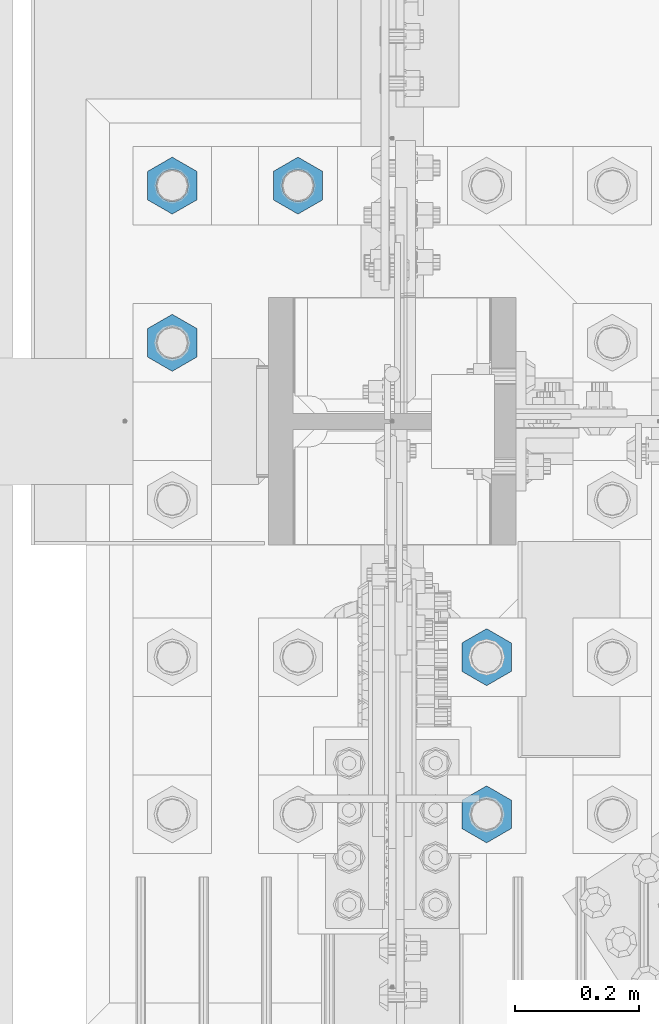
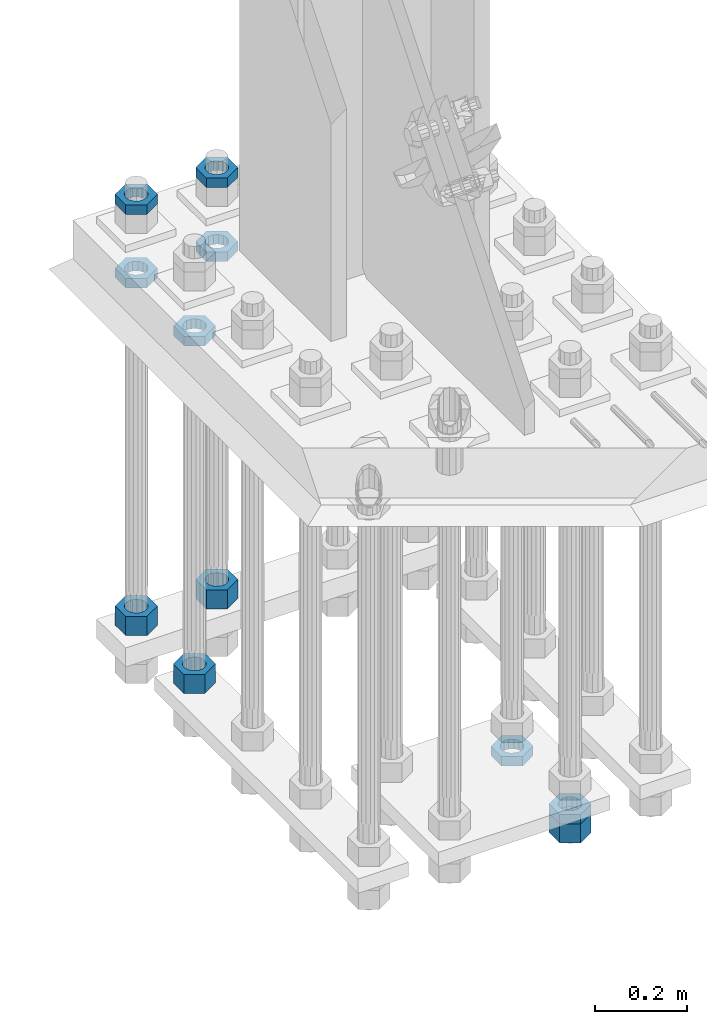
# One storey, part 2386 of 3843: 11 beams, 1 element without a shape of its own.
"""IFC2X3 building model written with IfcOpenShell, lengths in millimetres."""

from ifc_helpers import new_model, si_unit, frame, origin_with_axes, place, context, subcontext, project, spatial, faceted_brep, material, type_object, element, aggregate, save


model = new_model("IFC2X3")

# Units and contexts
model_context = context("Model", 3, precision=1e-05, world=origin_with_axes())
body_context = subcontext(model_context, "Body", "Model", "MODEL_VIEW")
ifc_project = project(units=[si_unit("LENGTHUNIT", "METRE", prefix="MILLI"), si_unit("AREAUNIT", "SQUARE_METRE"), si_unit("VOLUMEUNIT", "CUBIC_METRE"), si_unit("MASSUNIT", "GRAM", prefix="KILO"), si_unit("TIMEUNIT", "SECOND"), si_unit("PLANEANGLEUNIT", "RADIAN"), si_unit("SOLIDANGLEUNIT", "STERADIAN"), si_unit("THERMODYNAMICTEMPERATUREUNIT", "DEGREE_CELSIUS"), si_unit("LUMINOUSINTENSITYUNIT", "LUMEN")], contexts=[model_context])

# Site, building, storey
site_placement = place(None, origin_with_axes())
site = spatial("IfcSite", under=ifc_project, at=site_placement, CompositionType="ELEMENT")
building_placement = place(site_placement, origin_with_axes())
building = spatial("IfcBuilding", under=site, at=building_placement, Name="Undefined", CompositionType="ELEMENT")
storey_placement = place(building_placement, origin_with_axes())
storey = spatial("IfcBuildingStorey", under=building, at=storey_placement, Name="Undefined", CompositionType="ELEMENT", Elevation=0.0)

# Assembly, beams
assembly_placement = place(storey_placement, origin_with_axes())
assembly = element("IfcElementAssembly", 1, at=assembly_placement, inside=storey, Name="TEMPLATE", AssemblyPlace="NOTDEFINED", PredefinedType="RIGID_FRAME")
ifc_material = material(Name="STEEL/A572-50")
beam_type_1 = type_object("IfcBeamType", Name="2_HALF_NUT", PredefinedType="NOTDEFINED")
beam_1_placement = place(assembly_placement, frame((36220.4, 75755.5, 30060.9), z_axis=(1.0, 0.0, 0.0), x_axis=(0.0, 0.0, -1.0)))
beam_1 = element("IfcBeam", 2, at=beam_1_placement, type_object=beam_type_1, material=ifc_material, Name="NUT", ObjectType="2_HALF_NUT", context=body_context, shape_type="Brep", body=[
    faceted_brep([(0.0, -46.0369987487793, 0.0), (0.0, -23.0184993743896, -39.869213104248), (25.4000000000015, -23.0184993743896, -39.869213104248), (25.4000000000015, -46.0369987487793, 0.0), (0.0, 23.0184993743896, -39.869213104248), (25.4000000000015, 23.0184993743896, -39.869213104248), (0.0, 46.0369987487793, 0.0), (25.4000000000015, 46.0369987487793, 0.0), (0.0, 23.0184993743896, 39.869213104248), (25.4000000000015, 23.0184993743896, 39.869213104248), (0.0, -23.0184993743896, 39.869213104248), (25.4000000000015, -23.0184993743896, 39.869213104248), (0.0, 0.0, 26.1940002441406), (0.0, 11.3650617044477, 23.5999013092805), (25.4000000000015, 11.3650617044477, 23.5999013092805), (25.4000000000015, 0.0, 26.1940002441406), (0.0, 20.4791109456419, 16.3316083006721), (25.4000000000015, 20.4791109456419, 16.3316083006721), (0.0, 25.5370200498292, 5.82867859874386), (25.4000000000015, 25.5370200498292, 5.82867859874386), (0.0, 25.5370200498292, -5.82867859874386), (25.4000000000015, 25.5370200498292, -5.82867859874386), (0.0, 20.4791109456419, -16.3316083006721), (25.4000000000015, 20.4791109456419, -16.3316083006721), (0.0, 11.3650617044477, -23.5999013092805), (25.4000000000015, 11.3650617044477, -23.5999013092805), (0.0, 0.0, -26.1940002441406), (25.4000000000015, 0.0, -26.1940002441406), (0.0, -11.3650617044477, -23.5999013092805), (25.4000000000015, -11.3650617044477, -23.5999013092805), (0.0, -20.4791109456419, -16.3316083006721), (25.4000000000015, -20.4791109456419, -16.3316083006721), (0.0, -25.5370200498292, -5.82867859874386), (25.4000000000015, -25.5370200498292, -5.82867859874386), (0.0, -25.5370200498292, 5.82867859874386), (25.4000000000015, -25.5370200498292, 5.82867859874386), (0.0, -20.4791109456419, 16.3316083006721), (25.4000000000015, -20.4791109456419, 16.3316083006721), (0.0, -11.3650617044477, 23.5999013092805), (25.4000000000015, -11.3650617044477, 23.5999013092805)], [[[0, 1, 2, 3]], [[1, 4, 5, 2]], [[4, 6, 7, 5]], [[6, 8, 9, 7]], [[8, 10, 11, 9]], [[10, 0, 3, 11]], [[12, 13, 14, 15]], [[13, 16, 17, 14]], [[16, 18, 19, 17]], [[18, 20, 21, 19]], [[20, 22, 23, 21]], [[22, 24, 25, 23]], [[24, 26, 27, 25]], [[26, 28, 29, 27]], [[28, 30, 31, 29]], [[30, 32, 33, 31]], [[32, 34, 35, 33]], [[34, 36, 37, 35]], [[36, 38, 39, 37]], [[38, 12, 15, 39]], [[5, 7, 9, 11, 3, 2], [17, 19, 21, 23, 25, 27, 29, 31, 33, 35, 37, 39, 15, 14]], [[10, 8, 6, 4, 1, 0], [38, 36, 34, 32, 30, 28, 26, 24, 22, 20, 18, 16, 13, 12]]]),
])
beam_2_placement = place(assembly_placement, frame((36423.6, 76009.5, 30060.9), z_axis=(1.0, 0.0, 0.0), x_axis=(0.0, 0.0, -1.0)))
beam_2 = element("IfcBeam", 3, at=beam_2_placement, type_object=beam_type_1, material=ifc_material, Name="NUT", ObjectType="2_HALF_NUT", context=body_context, shape_type="Brep", body=[
    faceted_brep([(0.0, -46.0369987487793, 0.0), (0.0, -23.0184993743896, -39.869213104248), (25.4000000000015, -23.0184993743896, -39.869213104248), (25.4000000000015, -46.0369987487793, 0.0), (0.0, 23.0184993743896, -39.869213104248), (25.4000000000015, 23.0184993743896, -39.869213104248), (0.0, 46.0369987487793, 0.0), (25.4000000000015, 46.0369987487793, 0.0), (0.0, 23.0184993743896, 39.869213104248), (25.4000000000015, 23.0184993743896, 39.869213104248), (0.0, -23.0184993743896, 39.869213104248), (25.4000000000015, -23.0184993743896, 39.869213104248), (0.0, 0.0, 26.1940002441406), (0.0, 11.3650617044477, 23.5999013092805), (25.4000000000015, 11.3650617044477, 23.5999013092805), (25.4000000000015, 0.0, 26.1940002441406), (0.0, 20.4791109456419, 16.3316083006721), (25.4000000000015, 20.4791109456419, 16.3316083006721), (0.0, 25.5370200498292, 5.82867859874386), (25.4000000000015, 25.5370200498292, 5.82867859874386), (0.0, 25.5370200498292, -5.82867859874386), (25.4000000000015, 25.5370200498292, -5.82867859874386), (0.0, 20.4791109456419, -16.3316083006721), (25.4000000000015, 20.4791109456419, -16.3316083006721), (0.0, 11.3650617044477, -23.5999013092805), (25.4000000000015, 11.3650617044477, -23.5999013092805), (0.0, 0.0, -26.1940002441406), (25.4000000000015, 0.0, -26.1940002441406), (0.0, -11.3650617044477, -23.5999013092805), (25.4000000000015, -11.3650617044477, -23.5999013092805), (0.0, -20.4791109456419, -16.3316083006721), (25.4000000000015, -20.4791109456419, -16.3316083006721), (0.0, -25.5370200498292, -5.82867859874386), (25.4000000000015, -25.5370200498292, -5.82867859874386), (0.0, -25.5370200498292, 5.82867859874386), (25.4000000000015, -25.5370200498292, 5.82867859874386), (0.0, -20.4791109456419, 16.3316083006721), (25.4000000000015, -20.4791109456419, 16.3316083006721), (0.0, -11.3650617044477, 23.5999013092805), (25.4000000000015, -11.3650617044477, 23.5999013092805)], [[[0, 1, 2, 3]], [[1, 4, 5, 2]], [[4, 6, 7, 5]], [[6, 8, 9, 7]], [[8, 10, 11, 9]], [[10, 0, 3, 11]], [[12, 13, 14, 15]], [[13, 16, 17, 14]], [[16, 18, 19, 17]], [[18, 20, 21, 19]], [[20, 22, 23, 21]], [[22, 24, 25, 23]], [[24, 26, 27, 25]], [[26, 28, 29, 27]], [[28, 30, 31, 29]], [[30, 32, 33, 31]], [[32, 34, 35, 33]], [[34, 36, 37, 35]], [[36, 38, 39, 37]], [[38, 12, 15, 39]], [[5, 7, 9, 11, 3, 2], [17, 19, 21, 23, 25, 27, 29, 31, 33, 35, 37, 39, 15, 14]], [[10, 8, 6, 4, 1, 0], [38, 36, 34, 32, 30, 28, 26, 24, 22, 20, 18, 16, 13, 12]]]),
])
beam_3_placement = place(assembly_placement, frame((36220.4, 76009.5, 30060.9), z_axis=(1.0, 0.0, 0.0), x_axis=(0.0, 0.0, -1.0)))
beam_3 = element("IfcBeam", 4, at=beam_3_placement, type_object=beam_type_1, material=ifc_material, Name="NUT", ObjectType="2_HALF_NUT", context=body_context, shape_type="Brep", body=[
    faceted_brep([(0.0, -46.0369987487793, 0.0), (0.0, -23.0184993743896, -39.869213104248), (25.4000000000015, -23.0184993743896, -39.869213104248), (25.4000000000015, -46.0369987487793, 0.0), (0.0, 23.0184993743896, -39.869213104248), (25.4000000000015, 23.0184993743896, -39.869213104248), (0.0, 46.0369987487793, 0.0), (25.4000000000015, 46.0369987487793, 0.0), (0.0, 23.0184993743896, 39.869213104248), (25.4000000000015, 23.0184993743896, 39.869213104248), (0.0, -23.0184993743896, 39.869213104248), (25.4000000000015, -23.0184993743896, 39.869213104248), (0.0, 0.0, 26.1940002441406), (0.0, 11.3650617044477, 23.5999013092805), (25.4000000000015, 11.3650617044477, 23.5999013092805), (25.4000000000015, 0.0, 26.1940002441406), (0.0, 20.4791109456419, 16.3316083006721), (25.4000000000015, 20.4791109456419, 16.3316083006721), (0.0, 25.5370200498292, 5.82867859874386), (25.4000000000015, 25.5370200498292, 5.82867859874386), (0.0, 25.5370200498292, -5.82867859874386), (25.4000000000015, 25.5370200498292, -5.82867859874386), (0.0, 20.4791109456419, -16.3316083006721), (25.4000000000015, 20.4791109456419, -16.3316083006721), (0.0, 11.3650617044477, -23.5999013092805), (25.4000000000015, 11.3650617044477, -23.5999013092805), (0.0, 0.0, -26.1940002441406), (25.4000000000015, 0.0, -26.1940002441406), (0.0, -11.3650617044477, -23.5999013092805), (25.4000000000015, -11.3650617044477, -23.5999013092805), (0.0, -20.4791109456419, -16.3316083006721), (25.4000000000015, -20.4791109456419, -16.3316083006721), (0.0, -25.5370200498292, -5.82867859874386), (25.4000000000015, -25.5370200498292, -5.82867859874386), (0.0, -25.5370200498292, 5.82867859874386), (25.4000000000015, -25.5370200498292, 5.82867859874386), (0.0, -20.4791109456419, 16.3316083006721), (25.4000000000015, -20.4791109456419, 16.3316083006721), (0.0, -11.3650617044477, 23.5999013092805), (25.4000000000015, -11.3650617044477, 23.5999013092805)], [[[0, 1, 2, 3]], [[1, 4, 5, 2]], [[4, 6, 7, 5]], [[6, 8, 9, 7]], [[8, 10, 11, 9]], [[10, 0, 3, 11]], [[12, 13, 14, 15]], [[13, 16, 17, 14]], [[16, 18, 19, 17]], [[18, 20, 21, 19]], [[20, 22, 23, 21]], [[22, 24, 25, 23]], [[24, 26, 27, 25]], [[26, 28, 29, 27]], [[28, 30, 31, 29]], [[30, 32, 33, 31]], [[32, 34, 35, 33]], [[34, 36, 37, 35]], [[36, 38, 39, 37]], [[38, 12, 15, 39]], [[5, 7, 9, 11, 3, 2], [17, 19, 21, 23, 25, 27, 29, 31, 33, 35, 37, 39, 15, 14]], [[10, 8, 6, 4, 1, 0], [38, 36, 34, 32, 30, 28, 26, 24, 22, 20, 18, 16, 13, 12]]]),
])
beam_4_placement = place(assembly_placement, frame((36423.6, 76009.5, 30257.75), z_axis=(1.0, 0.0, 0.0), x_axis=(0.0, 0.0, -1.0)))
beam_4 = element("IfcBeam", 5, at=beam_4_placement, type_object=beam_type_1, material=ifc_material, Name="NUT", ObjectType="2_HALF_NUT", context=body_context, shape_type="Brep", body=[
    faceted_brep([(0.0, -46.0369987487793, 0.0), (0.0, -23.0184993743896, -39.869213104248), (25.4000000000015, -23.0184993743896, -39.869213104248), (25.4000000000015, -46.0369987487793, 0.0), (0.0, 23.0184993743896, -39.869213104248), (25.4000000000015, 23.0184993743896, -39.869213104248), (0.0, 46.0369987487793, 0.0), (25.4000000000015, 46.0369987487793, 0.0), (0.0, 23.0184993743896, 39.869213104248), (25.4000000000015, 23.0184993743896, 39.869213104248), (0.0, -23.0184993743896, 39.869213104248), (25.4000000000015, -23.0184993743896, 39.869213104248), (0.0, 0.0, 26.1940002441406), (0.0, 11.3650617044477, 23.5999013092805), (25.4000000000015, 11.3650617044477, 23.5999013092805), (25.4000000000015, 0.0, 26.1940002441406), (0.0, 20.4791109456419, 16.3316083006721), (25.4000000000015, 20.4791109456419, 16.3316083006721), (0.0, 25.5370200498292, 5.82867859874386), (25.4000000000015, 25.5370200498292, 5.82867859874386), (0.0, 25.5370200498292, -5.82867859874386), (25.4000000000015, 25.5370200498292, -5.82867859874386), (0.0, 20.4791109456419, -16.3316083006721), (25.4000000000015, 20.4791109456419, -16.3316083006721), (0.0, 11.3650617044477, -23.5999013092805), (25.4000000000015, 11.3650617044477, -23.5999013092805), (0.0, 0.0, -26.1940002441406), (25.4000000000015, 0.0, -26.1940002441406), (0.0, -11.3650617044477, -23.5999013092805), (25.4000000000015, -11.3650617044477, -23.5999013092805), (0.0, -20.4791109456419, -16.3316083006721), (25.4000000000015, -20.4791109456419, -16.3316083006721), (0.0, -25.5370200498292, -5.82867859874386), (25.4000000000015, -25.5370200498292, -5.82867859874386), (0.0, -25.5370200498292, 5.82867859874386), (25.4000000000015, -25.5370200498292, 5.82867859874386), (0.0, -20.4791109456419, 16.3316083006721), (25.4000000000015, -20.4791109456419, 16.3316083006721), (0.0, -11.3650617044477, 23.5999013092805), (25.4000000000015, -11.3650617044477, 23.5999013092805)], [[[0, 1, 2, 3]], [[1, 4, 5, 2]], [[4, 6, 7, 5]], [[6, 8, 9, 7]], [[8, 10, 11, 9]], [[10, 0, 3, 11]], [[12, 13, 14, 15]], [[13, 16, 17, 14]], [[16, 18, 19, 17]], [[18, 20, 21, 19]], [[20, 22, 23, 21]], [[22, 24, 25, 23]], [[24, 26, 27, 25]], [[26, 28, 29, 27]], [[28, 30, 31, 29]], [[30, 32, 33, 31]], [[32, 34, 35, 33]], [[34, 36, 37, 35]], [[36, 38, 39, 37]], [[38, 12, 15, 39]], [[5, 7, 9, 11, 3, 2], [17, 19, 21, 23, 25, 27, 29, 31, 33, 35, 37, 39, 15, 14]], [[10, 8, 6, 4, 1, 0], [38, 36, 34, 32, 30, 28, 26, 24, 22, 20, 18, 16, 13, 12]]]),
])
beam_5_placement = place(assembly_placement, frame((36220.4, 76009.5, 30257.75), z_axis=(1.0, 0.0, 0.0), x_axis=(0.0, 0.0, -1.0)))
beam_5 = element("IfcBeam", 6, at=beam_5_placement, type_object=beam_type_1, material=ifc_material, Name="NUT", ObjectType="2_HALF_NUT", context=body_context, shape_type="Brep", body=[
    faceted_brep([(0.0, -46.0369987487793, 0.0), (0.0, -23.0184993743896, -39.869213104248), (25.4000000000015, -23.0184993743896, -39.869213104248), (25.4000000000015, -46.0369987487793, 0.0), (0.0, 23.0184993743896, -39.869213104248), (25.4000000000015, 23.0184993743896, -39.869213104248), (0.0, 46.0369987487793, 0.0), (25.4000000000015, 46.0369987487793, 0.0), (0.0, 23.0184993743896, 39.869213104248), (25.4000000000015, 23.0184993743896, 39.869213104248), (0.0, -23.0184993743896, 39.869213104248), (25.4000000000015, -23.0184993743896, 39.869213104248), (0.0, 0.0, 26.1940002441406), (0.0, 11.3650617044477, 23.5999013092805), (25.4000000000015, 11.3650617044477, 23.5999013092805), (25.4000000000015, 0.0, 26.1940002441406), (0.0, 20.4791109456419, 16.3316083006721), (25.4000000000015, 20.4791109456419, 16.3316083006721), (0.0, 25.5370200498292, 5.82867859874386), (25.4000000000015, 25.5370200498292, 5.82867859874386), (0.0, 25.5370200498292, -5.82867859874386), (25.4000000000015, 25.5370200498292, -5.82867859874386), (0.0, 20.4791109456419, -16.3316083006721), (25.4000000000015, 20.4791109456419, -16.3316083006721), (0.0, 11.3650617044477, -23.5999013092805), (25.4000000000015, 11.3650617044477, -23.5999013092805), (0.0, 0.0, -26.1940002441406), (25.4000000000015, 0.0, -26.1940002441406), (0.0, -11.3650617044477, -23.5999013092805), (25.4000000000015, -11.3650617044477, -23.5999013092805), (0.0, -20.4791109456419, -16.3316083006721), (25.4000000000015, -20.4791109456419, -16.3316083006721), (0.0, -25.5370200498292, -5.82867859874386), (25.4000000000015, -25.5370200498292, -5.82867859874386), (0.0, -25.5370200498292, 5.82867859874386), (25.4000000000015, -25.5370200498292, 5.82867859874386), (0.0, -20.4791109456419, 16.3316083006721), (25.4000000000015, -20.4791109456419, 16.3316083006721), (0.0, -11.3650617044477, 23.5999013092805), (25.4000000000015, -11.3650617044477, 23.5999013092805)], [[[0, 1, 2, 3]], [[1, 4, 5, 2]], [[4, 6, 7, 5]], [[6, 8, 9, 7]], [[8, 10, 11, 9]], [[10, 0, 3, 11]], [[12, 13, 14, 15]], [[13, 16, 17, 14]], [[16, 18, 19, 17]], [[18, 20, 21, 19]], [[20, 22, 23, 21]], [[22, 24, 25, 23]], [[24, 26, 27, 25]], [[26, 28, 29, 27]], [[28, 30, 31, 29]], [[30, 32, 33, 31]], [[32, 34, 35, 33]], [[34, 36, 37, 35]], [[36, 38, 39, 37]], [[38, 12, 15, 39]], [[5, 7, 9, 11, 3, 2], [17, 19, 21, 23, 25, 27, 29, 31, 33, 35, 37, 39, 15, 14]], [[10, 8, 6, 4, 1, 0], [38, 36, 34, 32, 30, 28, 26, 24, 22, 20, 18, 16, 13, 12]]]),
])
beam_6_placement = place(assembly_placement, frame((36728.4, 75247.5, 29070.3), z_axis=(-1.0, 0.0, 0.0), x_axis=(0.0, 0.0, -1.0)))
beam_6 = element("IfcBeam", 7, at=beam_6_placement, type_object=beam_type_1, material=ifc_material, Name="NUT", ObjectType="2_HALF_NUT", context=body_context, shape_type="Brep", body=[
    faceted_brep([(0.0, -46.0369987487793, 0.0), (0.0, -23.0184993743896, -39.869213104248), (25.4000000000015, -23.0184993743896, -39.869213104248), (25.4000000000015, -46.0369987487793, 0.0), (0.0, 23.0184993743896, -39.869213104248), (25.4000000000015, 23.0184993743896, -39.869213104248), (0.0, 46.0369987487793, 0.0), (25.4000000000015, 46.0369987487793, 0.0), (0.0, 23.0184993743896, 39.869213104248), (25.4000000000015, 23.0184993743896, 39.869213104248), (0.0, -23.0184993743896, 39.869213104248), (25.4000000000015, -23.0184993743896, 39.869213104248), (0.0, 0.0, 26.1940002441406), (0.0, 11.3650617044477, 23.5999013092805), (25.4000000000015, 11.3650617044477, 23.5999013092805), (25.4000000000015, 0.0, 26.1940002441406), (0.0, 20.4791109456419, 16.3316083006721), (25.4000000000015, 20.4791109456419, 16.3316083006721), (0.0, 25.5370200498292, 5.82867859874386), (25.4000000000015, 25.5370200498292, 5.82867859874386), (0.0, 25.5370200498292, -5.82867859874386), (25.4000000000015, 25.5370200498292, -5.82867859874386), (0.0, 20.4791109456419, -16.3316083006721), (25.4000000000015, 20.4791109456419, -16.3316083006721), (0.0, 11.3650617044477, -23.5999013092805), (25.4000000000015, 11.3650617044477, -23.5999013092805), (0.0, 0.0, -26.1940002441406), (25.4000000000015, 0.0, -26.1940002441406), (0.0, -11.3650617044477, -23.5999013092805), (25.4000000000015, -11.3650617044477, -23.5999013092805), (0.0, -20.4791109456419, -16.3316083006721), (25.4000000000015, -20.4791109456419, -16.3316083006721), (0.0, -25.5370200498292, -5.82867859874386), (25.4000000000015, -25.5370200498292, -5.82867859874386), (0.0, -25.5370200498292, 5.82867859874386), (25.4000000000015, -25.5370200498292, 5.82867859874386), (0.0, -20.4791109456419, 16.3316083006721), (25.4000000000015, -20.4791109456419, 16.3316083006721), (0.0, -11.3650617044477, 23.5999013092805), (25.4000000000015, -11.3650617044477, 23.5999013092805)], [[[0, 1, 2, 3]], [[1, 4, 5, 2]], [[4, 6, 7, 5]], [[6, 8, 9, 7]], [[8, 10, 11, 9]], [[10, 0, 3, 11]], [[12, 13, 14, 15]], [[13, 16, 17, 14]], [[16, 18, 19, 17]], [[18, 20, 21, 19]], [[20, 22, 23, 21]], [[22, 24, 25, 23]], [[24, 26, 27, 25]], [[26, 28, 29, 27]], [[28, 30, 31, 29]], [[30, 32, 33, 31]], [[32, 34, 35, 33]], [[34, 36, 37, 35]], [[36, 38, 39, 37]], [[38, 12, 15, 39]], [[5, 7, 9, 11, 3, 2], [17, 19, 21, 23, 25, 27, 29, 31, 33, 35, 37, 39, 15, 14]], [[10, 8, 6, 4, 1, 0], [38, 36, 34, 32, 30, 28, 26, 24, 22, 20, 18, 16, 13, 12]]]),
])
beam_7_placement = place(assembly_placement, frame((36728.4, 74993.5, 29070.3), z_axis=(-1.0, 0.0, 0.0), x_axis=(0.0, 0.0, -1.0)))
beam_7 = element("IfcBeam", 8, at=beam_7_placement, type_object=beam_type_1, material=ifc_material, Name="NUT", ObjectType="2_HALF_NUT", context=body_context, shape_type="Brep", body=[
    faceted_brep([(0.0, -46.0369987487793, 0.0), (0.0, -23.0184993743896, -39.869213104248), (25.4000000000015, -23.0184993743896, -39.869213104248), (25.4000000000015, -46.0369987487793, 0.0), (0.0, 23.0184993743896, -39.869213104248), (25.4000000000015, 23.0184993743896, -39.869213104248), (0.0, 46.0369987487793, 0.0), (25.4000000000015, 46.0369987487793, 0.0), (0.0, 23.0184993743896, 39.869213104248), (25.4000000000015, 23.0184993743896, 39.869213104248), (0.0, -23.0184993743896, 39.869213104248), (25.4000000000015, -23.0184993743896, 39.869213104248), (0.0, 0.0, 26.1940002441406), (0.0, 11.3650617044477, 23.5999013092805), (25.4000000000015, 11.3650617044477, 23.5999013092805), (25.4000000000015, 0.0, 26.1940002441406), (0.0, 20.4791109456419, 16.3316083006721), (25.4000000000015, 20.4791109456419, 16.3316083006721), (0.0, 25.5370200498292, 5.82867859874386), (25.4000000000015, 25.5370200498292, 5.82867859874386), (0.0, 25.5370200498292, -5.82867859874386), (25.4000000000015, 25.5370200498292, -5.82867859874386), (0.0, 20.4791109456419, -16.3316083006721), (25.4000000000015, 20.4791109456419, -16.3316083006721), (0.0, 11.3650617044477, -23.5999013092805), (25.4000000000015, 11.3650617044477, -23.5999013092805), (0.0, 0.0, -26.1940002441406), (25.4000000000015, 0.0, -26.1940002441406), (0.0, -11.3650617044477, -23.5999013092805), (25.4000000000015, -11.3650617044477, -23.5999013092805), (0.0, -20.4791109456419, -16.3316083006721), (25.4000000000015, -20.4791109456419, -16.3316083006721), (0.0, -25.5370200498292, -5.82867859874386), (25.4000000000015, -25.5370200498292, -5.82867859874386), (0.0, -25.5370200498292, 5.82867859874386), (25.4000000000015, -25.5370200498292, 5.82867859874386), (0.0, -20.4791109456419, 16.3316083006721), (25.4000000000015, -20.4791109456419, 16.3316083006721), (0.0, -11.3650617044477, 23.5999013092805), (25.4000000000015, -11.3650617044477, 23.5999013092805)], [[[0, 1, 2, 3]], [[1, 4, 5, 2]], [[4, 6, 7, 5]], [[6, 8, 9, 7]], [[8, 10, 11, 9]], [[10, 0, 3, 11]], [[12, 13, 14, 15]], [[13, 16, 17, 14]], [[16, 18, 19, 17]], [[18, 20, 21, 19]], [[20, 22, 23, 21]], [[22, 24, 25, 23]], [[24, 26, 27, 25]], [[26, 28, 29, 27]], [[28, 30, 31, 29]], [[30, 32, 33, 31]], [[32, 34, 35, 33]], [[34, 36, 37, 35]], [[36, 38, 39, 37]], [[38, 12, 15, 39]], [[5, 7, 9, 11, 3, 2], [17, 19, 21, 23, 25, 27, 29, 31, 33, 35, 37, 39, 15, 14]], [[10, 8, 6, 4, 1, 0], [38, 36, 34, 32, 30, 28, 26, 24, 22, 20, 18, 16, 13, 12]]]),
])
beam_type_2 = type_object("IfcBeamType", Name="2_HEAVY_HEX_NUT", PredefinedType="NOTDEFINED")
beam_8_placement = place(assembly_placement, frame((36423.6, 76009.5, 29159.2), z_axis=(1.0, 0.0, 0.0), x_axis=(0.0, 0.0, -1.0)))
beam_8 = element("IfcBeam", 9, at=beam_8_placement, type_object=beam_type_2, material=ifc_material, Name="NUT", ObjectType="2_HEAVY_HEX_NUT", context=body_context, shape_type="Brep", body=[
    faceted_brep([(0.0, -46.0369987487793, 0.0), (0.0, -23.0184993743896, -39.869213104248), (50.7999999999993, -23.0184993743896, -39.869213104248), (50.7999999999993, -46.0369987487793, 0.0), (0.0, 23.0184993743896, -39.869213104248), (50.7999999999993, 23.0184993743896, -39.869213104248), (0.0, 46.0369987487793, 0.0), (50.7999999999993, 46.0369987487793, 0.0), (0.0, 23.0184993743896, 39.869213104248), (50.7999999999993, 23.0184993743896, 39.869213104248), (0.0, -23.0184993743896, 39.869213104248), (50.7999999999993, -23.0184993743896, 39.869213104248), (0.0, 0.0, 26.1940002441406), (0.0, 11.3650617044477, 23.5999013092805), (50.7999999999993, 11.3650617044477, 23.5999013092805), (50.7999999999993, 0.0, 26.1940002441406), (0.0, 20.4791109456419, 16.3316083006721), (50.7999999999993, 20.4791109456419, 16.3316083006721), (0.0, 25.5370200498292, 5.82867859874386), (50.7999999999993, 25.5370200498292, 5.82867859874386), (0.0, 25.5370200498292, -5.82867859874386), (50.7999999999993, 25.5370200498292, -5.82867859874386), (0.0, 20.4791109456419, -16.3316083006721), (50.7999999999993, 20.4791109456419, -16.3316083006721), (0.0, 11.3650617044477, -23.5999013092805), (50.7999999999993, 11.3650617044477, -23.5999013092805), (0.0, 0.0, -26.1940002441406), (50.7999999999993, 0.0, -26.1940002441406), (0.0, -11.3650617044477, -23.5999013092805), (50.7999999999993, -11.3650617044477, -23.5999013092805), (0.0, -20.4791109456419, -16.3316083006721), (50.7999999999993, -20.4791109456419, -16.3316083006721), (0.0, -25.5370200498292, -5.82867859874386), (50.7999999999993, -25.5370200498292, -5.82867859874386), (0.0, -25.5370200498292, 5.82867859874386), (50.7999999999993, -25.5370200498292, 5.82867859874386), (0.0, -20.4791109456419, 16.3316083006721), (50.7999999999993, -20.4791109456419, 16.3316083006721), (0.0, -11.3650617044477, 23.5999013092805), (50.7999999999993, -11.3650617044477, 23.5999013092805)], [[[0, 1, 2, 3]], [[1, 4, 5, 2]], [[4, 6, 7, 5]], [[6, 8, 9, 7]], [[8, 10, 11, 9]], [[10, 0, 3, 11]], [[12, 13, 14, 15]], [[13, 16, 17, 14]], [[16, 18, 19, 17]], [[18, 20, 21, 19]], [[20, 22, 23, 21]], [[22, 24, 25, 23]], [[24, 26, 27, 25]], [[26, 28, 29, 27]], [[28, 30, 31, 29]], [[30, 32, 33, 31]], [[32, 34, 35, 33]], [[34, 36, 37, 35]], [[36, 38, 39, 37]], [[38, 12, 15, 39]], [[5, 7, 9, 11, 3, 2], [17, 19, 21, 23, 25, 27, 29, 31, 33, 35, 37, 39, 15, 14]], [[10, 8, 6, 4, 1, 0], [38, 36, 34, 32, 30, 28, 26, 24, 22, 20, 18, 16, 13, 12]]]),
])
beam_9_placement = place(assembly_placement, frame((36220.4, 76009.5, 29159.2), z_axis=(1.0, 0.0, 0.0), x_axis=(0.0, 0.0, -1.0)))
beam_9 = element("IfcBeam", 10, at=beam_9_placement, type_object=beam_type_2, material=ifc_material, Name="NUT", ObjectType="2_HEAVY_HEX_NUT", context=body_context, shape_type="Brep", body=[
    faceted_brep([(0.0, -46.0369987487793, 0.0), (0.0, -23.0184993743896, -39.869213104248), (50.7999999999993, -23.0184993743896, -39.869213104248), (50.7999999999993, -46.0369987487793, 0.0), (0.0, 23.0184993743896, -39.869213104248), (50.7999999999993, 23.0184993743896, -39.869213104248), (0.0, 46.0369987487793, 0.0), (50.7999999999993, 46.0369987487793, 0.0), (0.0, 23.0184993743896, 39.869213104248), (50.7999999999993, 23.0184993743896, 39.869213104248), (0.0, -23.0184993743896, 39.869213104248), (50.7999999999993, -23.0184993743896, 39.869213104248), (0.0, 0.0, 26.1940002441406), (0.0, 11.3650617044477, 23.5999013092805), (50.7999999999993, 11.3650617044477, 23.5999013092805), (50.7999999999993, 0.0, 26.1940002441406), (0.0, 20.4791109456419, 16.3316083006721), (50.7999999999993, 20.4791109456419, 16.3316083006721), (0.0, 25.5370200498292, 5.82867859874386), (50.7999999999993, 25.5370200498292, 5.82867859874386), (0.0, 25.5370200498292, -5.82867859874386), (50.7999999999993, 25.5370200498292, -5.82867859874386), (0.0, 20.4791109456419, -16.3316083006721), (50.7999999999993, 20.4791109456419, -16.3316083006721), (0.0, 11.3650617044477, -23.5999013092805), (50.7999999999993, 11.3650617044477, -23.5999013092805), (0.0, 0.0, -26.1940002441406), (50.7999999999993, 0.0, -26.1940002441406), (0.0, -11.3650617044477, -23.5999013092805), (50.7999999999993, -11.3650617044477, -23.5999013092805), (0.0, -20.4791109456419, -16.3316083006721), (50.7999999999993, -20.4791109456419, -16.3316083006721), (0.0, -25.5370200498292, -5.82867859874386), (50.7999999999993, -25.5370200498292, -5.82867859874386), (0.0, -25.5370200498292, 5.82867859874386), (50.7999999999993, -25.5370200498292, 5.82867859874386), (0.0, -20.4791109456419, 16.3316083006721), (50.7999999999993, -20.4791109456419, 16.3316083006721), (0.0, -11.3650617044477, 23.5999013092805), (50.7999999999993, -11.3650617044477, 23.5999013092805)], [[[0, 1, 2, 3]], [[1, 4, 5, 2]], [[4, 6, 7, 5]], [[6, 8, 9, 7]], [[8, 10, 11, 9]], [[10, 0, 3, 11]], [[12, 13, 14, 15]], [[13, 16, 17, 14]], [[16, 18, 19, 17]], [[18, 20, 21, 19]], [[20, 22, 23, 21]], [[22, 24, 25, 23]], [[24, 26, 27, 25]], [[26, 28, 29, 27]], [[28, 30, 31, 29]], [[30, 32, 33, 31]], [[32, 34, 35, 33]], [[34, 36, 37, 35]], [[36, 38, 39, 37]], [[38, 12, 15, 39]], [[5, 7, 9, 11, 3, 2], [17, 19, 21, 23, 25, 27, 29, 31, 33, 35, 37, 39, 15, 14]], [[10, 8, 6, 4, 1, 0], [38, 36, 34, 32, 30, 28, 26, 24, 22, 20, 18, 16, 13, 12]]]),
])
beam_10_placement = place(assembly_placement, frame((36220.4, 75755.5, 29159.2), z_axis=(1.0, 0.0, 0.0), x_axis=(0.0, 0.0, -1.0)))
beam_10 = element("IfcBeam", 11, at=beam_10_placement, type_object=beam_type_2, material=ifc_material, Name="NUT", ObjectType="2_HEAVY_HEX_NUT", context=body_context, shape_type="Brep", body=[
    faceted_brep([(0.0, -46.0369987487793, 0.0), (0.0, -23.0184993743896, -39.869213104248), (50.7999999999993, -23.0184993743896, -39.869213104248), (50.7999999999993, -46.0369987487793, 0.0), (0.0, 23.0184993743896, -39.869213104248), (50.7999999999993, 23.0184993743896, -39.869213104248), (0.0, 46.0369987487793, 0.0), (50.7999999999993, 46.0369987487793, 0.0), (0.0, 23.0184993743896, 39.869213104248), (50.7999999999993, 23.0184993743896, 39.869213104248), (0.0, -23.0184993743896, 39.869213104248), (50.7999999999993, -23.0184993743896, 39.869213104248), (0.0, 0.0, 26.1940002441406), (0.0, 11.3650617044477, 23.5999013092805), (50.7999999999993, 11.3650617044477, 23.5999013092805), (50.7999999999993, 0.0, 26.1940002441406), (0.0, 20.4791109456419, 16.3316083006721), (50.7999999999993, 20.4791109456419, 16.3316083006721), (0.0, 25.5370200498292, 5.82867859874386), (50.7999999999993, 25.5370200498292, 5.82867859874386), (0.0, 25.5370200498292, -5.82867859874386), (50.7999999999993, 25.5370200498292, -5.82867859874386), (0.0, 20.4791109456419, -16.3316083006721), (50.7999999999993, 20.4791109456419, -16.3316083006721), (0.0, 11.3650617044477, -23.5999013092805), (50.7999999999993, 11.3650617044477, -23.5999013092805), (0.0, 0.0, -26.1940002441406), (50.7999999999993, 0.0, -26.1940002441406), (0.0, -11.3650617044477, -23.5999013092805), (50.7999999999993, -11.3650617044477, -23.5999013092805), (0.0, -20.4791109456419, -16.3316083006721), (50.7999999999993, -20.4791109456419, -16.3316083006721), (0.0, -25.5370200498292, -5.82867859874386), (50.7999999999993, -25.5370200498292, -5.82867859874386), (0.0, -25.5370200498292, 5.82867859874386), (50.7999999999993, -25.5370200498292, 5.82867859874386), (0.0, -20.4791109456419, 16.3316083006721), (50.7999999999993, -20.4791109456419, 16.3316083006721), (0.0, -11.3650617044477, 23.5999013092805), (50.7999999999993, -11.3650617044477, 23.5999013092805)], [[[0, 1, 2, 3]], [[1, 4, 5, 2]], [[4, 6, 7, 5]], [[6, 8, 9, 7]], [[8, 10, 11, 9]], [[10, 0, 3, 11]], [[12, 13, 14, 15]], [[13, 16, 17, 14]], [[16, 18, 19, 17]], [[18, 20, 21, 19]], [[20, 22, 23, 21]], [[22, 24, 25, 23]], [[24, 26, 27, 25]], [[26, 28, 29, 27]], [[28, 30, 31, 29]], [[30, 32, 33, 31]], [[32, 34, 35, 33]], [[34, 36, 37, 35]], [[36, 38, 39, 37]], [[38, 12, 15, 39]], [[5, 7, 9, 11, 3, 2], [17, 19, 21, 23, 25, 27, 29, 31, 33, 35, 37, 39, 15, 14]], [[10, 8, 6, 4, 1, 0], [38, 36, 34, 32, 30, 28, 26, 24, 22, 20, 18, 16, 13, 12]]]),
])
beam_11_placement = place(assembly_placement, frame((36728.4, 74993.5, 29044.9), z_axis=(-1.0, 0.0, 0.0), x_axis=(0.0, 0.0, -1.0)))
beam_11 = element("IfcBeam", 12, at=beam_11_placement, type_object=beam_type_2, material=ifc_material, Name="NUT", ObjectType="2_HEAVY_HEX_NUT", context=body_context, shape_type="Brep", body=[
    faceted_brep([(0.0, -46.0369987487793, 0.0), (0.0, -23.0184993743896, -39.869213104248), (50.7999999999993, -23.0184993743896, -39.869213104248), (50.7999999999993, -46.0369987487793, 0.0), (0.0, 23.0184993743896, -39.869213104248), (50.7999999999993, 23.0184993743896, -39.869213104248), (0.0, 46.0369987487793, 0.0), (50.7999999999993, 46.0369987487793, 0.0), (0.0, 23.0184993743896, 39.869213104248), (50.7999999999993, 23.0184993743896, 39.869213104248), (0.0, -23.0184993743896, 39.869213104248), (50.7999999999993, -23.0184993743896, 39.869213104248), (0.0, 0.0, 26.1940002441406), (0.0, 11.3650617044477, 23.5999013092805), (50.7999999999993, 11.3650617044477, 23.5999013092805), (50.7999999999993, 0.0, 26.1940002441406), (0.0, 20.4791109456419, 16.3316083006721), (50.7999999999993, 20.4791109456419, 16.3316083006721), (0.0, 25.5370200498292, 5.82867859874386), (50.7999999999993, 25.5370200498292, 5.82867859874386), (0.0, 25.5370200498292, -5.82867859874386), (50.7999999999993, 25.5370200498292, -5.82867859874386), (0.0, 20.4791109456419, -16.3316083006721), (50.7999999999993, 20.4791109456419, -16.3316083006721), (0.0, 11.3650617044477, -23.5999013092805), (50.7999999999993, 11.3650617044477, -23.5999013092805), (0.0, 0.0, -26.1940002441406), (50.7999999999993, 0.0, -26.1940002441406), (0.0, -11.3650617044477, -23.5999013092805), (50.7999999999993, -11.3650617044477, -23.5999013092805), (0.0, -20.4791109456419, -16.3316083006721), (50.7999999999993, -20.4791109456419, -16.3316083006721), (0.0, -25.5370200498292, -5.82867859874386), (50.7999999999993, -25.5370200498292, -5.82867859874386), (0.0, -25.5370200498292, 5.82867859874386), (50.7999999999993, -25.5370200498292, 5.82867859874386), (0.0, -20.4791109456419, 16.3316083006721), (50.7999999999993, -20.4791109456419, 16.3316083006721), (0.0, -11.3650617044477, 23.5999013092805), (50.7999999999993, -11.3650617044477, 23.5999013092805)], [[[0, 1, 2, 3]], [[1, 4, 5, 2]], [[4, 6, 7, 5]], [[6, 8, 9, 7]], [[8, 10, 11, 9]], [[10, 0, 3, 11]], [[12, 13, 14, 15]], [[13, 16, 17, 14]], [[16, 18, 19, 17]], [[18, 20, 21, 19]], [[20, 22, 23, 21]], [[22, 24, 25, 23]], [[24, 26, 27, 25]], [[26, 28, 29, 27]], [[28, 30, 31, 29]], [[30, 32, 33, 31]], [[32, 34, 35, 33]], [[34, 36, 37, 35]], [[36, 38, 39, 37]], [[38, 12, 15, 39]], [[5, 7, 9, 11, 3, 2], [17, 19, 21, 23, 25, 27, 29, 31, 33, 35, 37, 39, 15, 14]], [[10, 8, 6, 4, 1, 0], [38, 36, 34, 32, 30, 28, 26, 24, 22, 20, 18, 16, 13, 12]]]),
])
aggregate(assembly, [beam_8, beam_9, beam_10, beam_1, beam_2, beam_3, beam_4, beam_5, beam_6, beam_11, beam_7])

save(model, "model.ifc")
